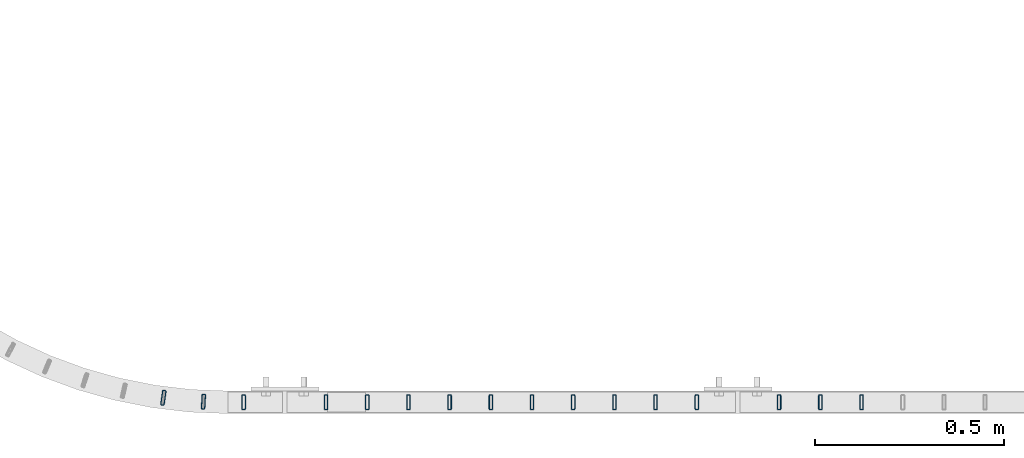
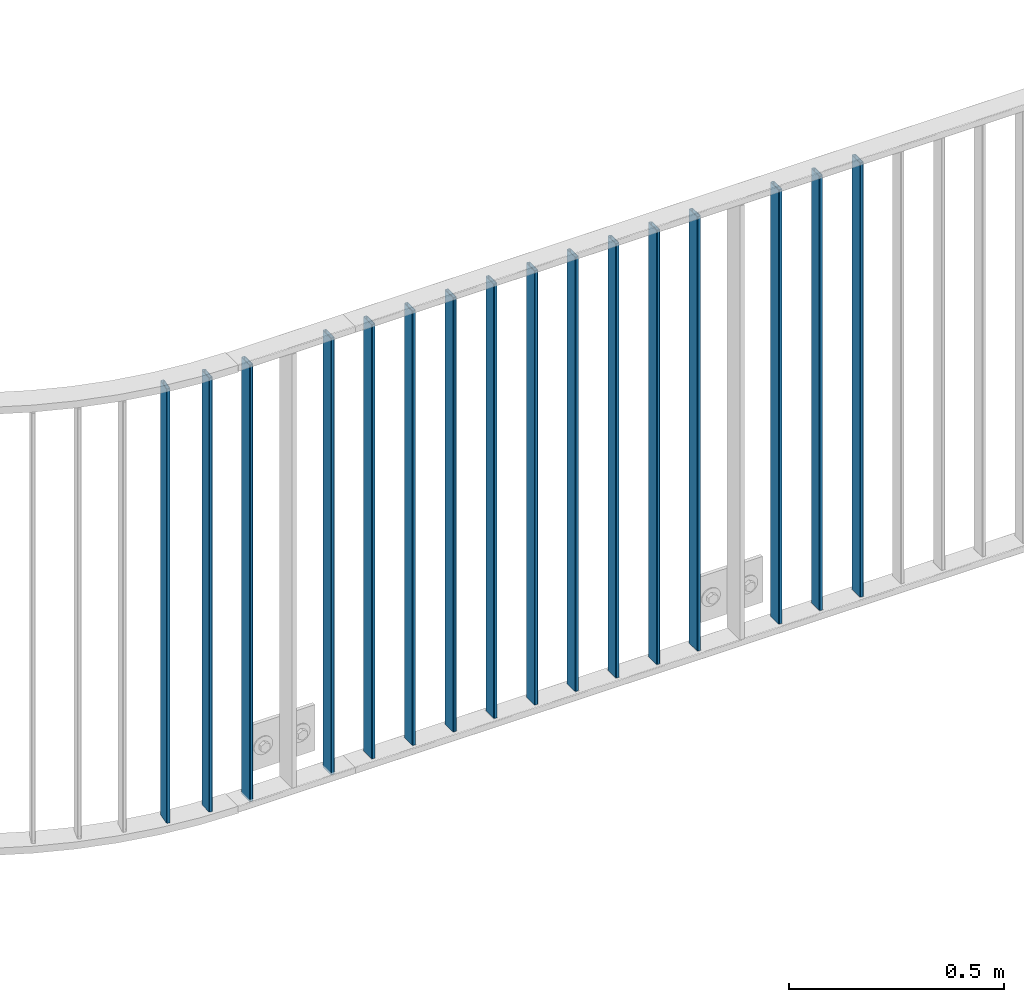
# One storey, part 18 of 156: 16 beams, 2 elements without a shape of their own.
"""IFC2X3 building model written with IfcOpenShell, lengths in millimetres."""

from ifc_helpers import new_model, si_unit, frame, origin_with_axes, origin_2d_with_axis, place, context, subcontext, project, spatial, hollow_rectangle, extrude, clip, halfspace, material, type_object, element, aggregate, save


model = new_model("IFC2X3")

# Units and contexts
model_context = context("Model", 3, precision=1e-05, world=origin_with_axes())
body_context = subcontext(model_context, "Body", "Model", "MODEL_VIEW")
ifc_project = project(units=[si_unit("LENGTHUNIT", "METRE", prefix="MILLI"), si_unit("AREAUNIT", "SQUARE_METRE"), si_unit("VOLUMEUNIT", "CUBIC_METRE"), si_unit("MASSUNIT", "GRAM", prefix="KILO"), si_unit("TIMEUNIT", "SECOND"), si_unit("PLANEANGLEUNIT", "RADIAN"), si_unit("SOLIDANGLEUNIT", "STERADIAN"), si_unit("THERMODYNAMICTEMPERATUREUNIT", "DEGREE_CELSIUS"), si_unit("LUMINOUSINTENSITYUNIT", "LUMEN")], contexts=[model_context])

# Site, building, storey
site_placement = place(None, origin_with_axes())
site = spatial("IfcSite", under=ifc_project, at=site_placement, CompositionType="ELEMENT")
building_placement = place(site_placement, origin_with_axes())
building = spatial("IfcBuilding", under=site, at=building_placement, Name="Undefined", CompositionType="ELEMENT")
storey_placement = place(building_placement, origin_with_axes())
storey = spatial("IfcBuildingStorey", under=building, at=storey_placement, Name="Undefined", CompositionType="ELEMENT", Elevation=0.0)

# Assembly, beams
assembly_1_placement = place(storey_placement, origin_with_axes())
assembly_1 = element("IfcElementAssembly", 1, at=assembly_1_placement, inside=storey, AssemblyPlace="NOTDEFINED", PredefinedType="RIGID_FRAME")
ifc_material = material(Name="STEEL/S235JR")
beam_type = type_object("IfcBeamType", Name="K40/10/1.5", PredefinedType="NOTDEFINED")
beam_1_placement = place(assembly_1_placement, frame((28384.3403545972, 8481.68386392733, 3980.00000000003), z_axis=(0.0588596310004505, 0.998266269007669, 0.0), x_axis=(0.0, 0.0, -1.0)))
beam_1 = element("IfcBeam", 2, at=beam_1_placement, type_object=beam_type, material=ifc_material, ObjectType="K40/10/1.5", context=body_context, shape_type="SweptSolid", body=[
    extrude(hollow_rectangle(XDim=10.0, YDim=40.0, WallThickness=1.5, InnerFilletRadius=1.5, OuterFilletRadius=3.0, at=origin_2d_with_axis()), frame((1230.0, 0.0, 0.0), z_axis=(-1.0, 0.0, 0.0), x_axis=(0.0, -1.0, 0.0)), (0.0, 0.0, 1.0), 1230.0),
])
beam_2_placement = place(assembly_1_placement, frame((28278.1852240979, 8491.69336136785, 3980.00000000003), z_axis=(0.143049714033372, 0.989715504230873, 0.0), x_axis=(0.0, 0.0, -1.0)))
beam_2 = element("IfcBeam", 3, at=beam_2_placement, type_object=beam_type, material=ifc_material, ObjectType="K40/10/1.5", context=body_context, shape_type="SweptSolid", body=[
    extrude(hollow_rectangle(XDim=10.0, YDim=40.0, WallThickness=1.5, InnerFilletRadius=1.5, OuterFilletRadius=3.0, at=origin_2d_with_axis()), frame((1230.0, 0.0, 0.0), z_axis=(-1.0, 0.0, 0.0), x_axis=(0.0, -1.0, 0.0)), (0.0, 0.0, 1.0), 1230.0),
])
beam_3_placement = place(assembly_1_placement, frame((28490.919999999, 8480.00209815304, 3980.00000000003), z_axis=(0.0, 1.0, 0.0), x_axis=(0.0, 0.0, -1.0)))
beam_3 = element("IfcBeam", 4, at=beam_3_placement, type_object=beam_type, material=ifc_material, ObjectType="K40/10/1.5", context=body_context, shape_type="Clipping", body=[
    clip(extrude(hollow_rectangle(XDim=10.0, YDim=40.0, WallThickness=1.5, InnerFilletRadius=1.5, OuterFilletRadius=3.0, at=origin_2d_with_axis()), frame((1237.00000000003, 0.0, 0.0), z_axis=(-1.0, 0.0, 0.0), x_axis=(0.0, -1.0, 0.0)), (0.0, 0.0, 1.0), 1237.0), halfspace(frame((1237.00000000003, 4.34248751949781, 47.3810900558092), z_axis=(1.0, 0.0, 0.0), x_axis=(0.0, -0.768354814194188, -0.640024124158313)), False)),
])
beam_4_placement = place(assembly_1_placement, frame((28709.099999999, 8480.00209815304, 3980.00000000003), z_axis=(0.0, 1.0, 0.0), x_axis=(0.0, 0.0, -1.0)))
beam_4 = element("IfcBeam", 5, at=beam_4_placement, type_object=beam_type, material=ifc_material, ObjectType="K40/10/1.5", context=body_context, shape_type="Clipping", body=[
    clip(extrude(hollow_rectangle(XDim=10.0, YDim=40.0, WallThickness=1.5, InnerFilletRadius=1.5, OuterFilletRadius=3.0, at=origin_2d_with_axis()), frame((1237.00000000003, 0.0, 0.0), z_axis=(-1.0, 0.0, 0.0), x_axis=(0.0, -1.0, 0.0)), (0.0, 0.0, 1.0), 1237.0), halfspace(frame((1237.00000000003, 4.34248751949781, 47.3810900558092), z_axis=(1.0, 0.0, 0.0), x_axis=(0.0, -0.768354814194188, -0.640024124158313)), False)),
])
aggregate(assembly_1, [beam_1, beam_2, beam_3, beam_4])

assembly_2_placement = place(storey_placement, origin_with_axes())
assembly_2 = element("IfcElementAssembly", 6, at=assembly_2_placement, inside=storey, AssemblyPlace="NOTDEFINED", PredefinedType="RIGID_FRAME")
beam_5_placement = place(assembly_2_placement, frame((28818.189999999, 8480.00209815304, 3980.00000000003), z_axis=(0.0, 1.0, 0.0), x_axis=(0.0, 0.0, -1.0)))
beam_5 = element("IfcBeam", 7, at=beam_5_placement, type_object=beam_type, material=ifc_material, ObjectType="K40/10/1.5", context=body_context, shape_type="Clipping", body=[
    clip(extrude(hollow_rectangle(XDim=10.0, YDim=40.0, WallThickness=1.5, InnerFilletRadius=1.5, OuterFilletRadius=3.0, at=origin_2d_with_axis()), frame((1230.0, 0.0, 0.0), z_axis=(-1.0, 0.0, 0.0), x_axis=(0.0, -1.0, 0.0)), (0.0, 0.0, 1.0), 1230.0), halfspace(frame((-6.99999999997453, -4.34248751950508, 47.3810900558092), z_axis=(-1.0, 0.0, 0.0), x_axis=(0.0, 0.7683548141934, -0.640024124159258)), False)),
])
beam_6_placement = place(assembly_2_placement, frame((28927.279999999, 8480.00209815304, 3980.00000000003), z_axis=(0.0, 1.0, 0.0), x_axis=(0.0, 0.0, -1.0)))
beam_6 = element("IfcBeam", 8, at=beam_6_placement, type_object=beam_type, material=ifc_material, ObjectType="K40/10/1.5", context=body_context, shape_type="Clipping", body=[
    clip(extrude(hollow_rectangle(XDim=10.0, YDim=40.0, WallThickness=1.5, InnerFilletRadius=1.5, OuterFilletRadius=3.0, at=origin_2d_with_axis()), frame((1230.0, 0.0, 0.0), z_axis=(-1.0, 0.0, 0.0), x_axis=(0.0, -1.0, 0.0)), (0.0, 0.0, 1.0), 1230.0), halfspace(frame((-6.99999999997453, -4.34248751950508, 47.3810900558092), z_axis=(-1.0, 0.0, 0.0), x_axis=(0.0, 0.7683548141934, -0.640024124159258)), False)),
])
beam_7_placement = place(assembly_2_placement, frame((29036.369999999, 8480.00209815304, 3980.00000000003), z_axis=(0.0, 1.0, 0.0), x_axis=(0.0, 0.0, -1.0)))
beam_7 = element("IfcBeam", 9, at=beam_7_placement, type_object=beam_type, material=ifc_material, ObjectType="K40/10/1.5", context=body_context, shape_type="Clipping", body=[
    clip(extrude(hollow_rectangle(XDim=10.0, YDim=40.0, WallThickness=1.5, InnerFilletRadius=1.5, OuterFilletRadius=3.0, at=origin_2d_with_axis()), frame((1230.0, 0.0, 0.0), z_axis=(-1.0, 0.0, 0.0), x_axis=(0.0, -1.0, 0.0)), (0.0, 0.0, 1.0), 1230.0), halfspace(frame((-6.99999999997453, -4.34248751950508, 47.3810900558092), z_axis=(-1.0, 0.0, 0.0), x_axis=(0.0, 0.7683548141934, -0.640024124159258)), False)),
])
beam_8_placement = place(assembly_2_placement, frame((29690.909999999, 8480.00209815304, 3980.00000000003), z_axis=(0.0, 1.0, 0.0), x_axis=(0.0, 0.0, -1.0)))
beam_8 = element("IfcBeam", 10, at=beam_8_placement, type_object=beam_type, material=ifc_material, ObjectType="K40/10/1.5", context=body_context, shape_type="Clipping", body=[
    clip(extrude(hollow_rectangle(XDim=10.0, YDim=40.0, WallThickness=1.5, InnerFilletRadius=1.5, OuterFilletRadius=3.0, at=origin_2d_with_axis()), frame((1230.0, 0.0, 0.0), z_axis=(-1.0, 0.0, 0.0), x_axis=(0.0, -1.0, 0.0)), (0.0, 0.0, 1.0), 1230.0), halfspace(frame((-6.99999999997453, -4.34248751950508, 47.3810900558092), z_axis=(-1.0, 0.0, 0.0), x_axis=(0.0, 0.7683548141934, -0.640024124159258)), False)),
])
beam_9_placement = place(assembly_2_placement, frame((29581.819999999, 8480.00209815304, 3980.00000000003), z_axis=(0.0, 1.0, 0.0), x_axis=(0.0, 0.0, -1.0)))
beam_9 = element("IfcBeam", 11, at=beam_9_placement, type_object=beam_type, material=ifc_material, ObjectType="K40/10/1.5", context=body_context, shape_type="Clipping", body=[
    clip(extrude(hollow_rectangle(XDim=10.0, YDim=40.0, WallThickness=1.5, InnerFilletRadius=1.5, OuterFilletRadius=3.0, at=origin_2d_with_axis()), frame((1230.0, 0.0, 0.0), z_axis=(-1.0, 0.0, 0.0), x_axis=(0.0, -1.0, 0.0)), (0.0, 0.0, 1.0), 1230.0), halfspace(frame((-6.99999999997453, -4.34248751950508, 47.3810900558092), z_axis=(-1.0, 0.0, 0.0), x_axis=(0.0, 0.7683548141934, -0.640024124159258)), False)),
])
beam_10_placement = place(assembly_2_placement, frame((29472.729999999, 8480.00209815304, 3980.00000000003), z_axis=(0.0, 1.0, 0.0), x_axis=(0.0, 0.0, -1.0)))
beam_10 = element("IfcBeam", 12, at=beam_10_placement, type_object=beam_type, material=ifc_material, ObjectType="K40/10/1.5", context=body_context, shape_type="Clipping", body=[
    clip(extrude(hollow_rectangle(XDim=10.0, YDim=40.0, WallThickness=1.5, InnerFilletRadius=1.5, OuterFilletRadius=3.0, at=origin_2d_with_axis()), frame((1230.0, 0.0, 0.0), z_axis=(-1.0, 0.0, 0.0), x_axis=(0.0, -1.0, 0.0)), (0.0, 0.0, 1.0), 1230.0), halfspace(frame((-6.99999999997453, -4.34248751950508, 47.3810900558092), z_axis=(-1.0, 0.0, 0.0), x_axis=(0.0, 0.7683548141934, -0.640024124159258)), False)),
])
beam_11_placement = place(assembly_2_placement, frame((29363.639999999, 8480.00209815304, 3980.00000000003), z_axis=(0.0, 1.0, 0.0), x_axis=(0.0, 0.0, -1.0)))
beam_11 = element("IfcBeam", 13, at=beam_11_placement, type_object=beam_type, material=ifc_material, ObjectType="K40/10/1.5", context=body_context, shape_type="Clipping", body=[
    clip(extrude(hollow_rectangle(XDim=10.0, YDim=40.0, WallThickness=1.5, InnerFilletRadius=1.5, OuterFilletRadius=3.0, at=origin_2d_with_axis()), frame((1230.0, 0.0, 0.0), z_axis=(-1.0, 0.0, 0.0), x_axis=(0.0, -1.0, 0.0)), (0.0, 0.0, 1.0), 1230.0), halfspace(frame((-6.99999999997453, -4.34248751950508, 47.3810900558092), z_axis=(-1.0, 0.0, 0.0), x_axis=(0.0, 0.7683548141934, -0.640024124159258)), False)),
])
beam_12_placement = place(assembly_2_placement, frame((29254.549999999, 8480.00209815304, 3980.00000000003), z_axis=(0.0, 1.0, 0.0), x_axis=(0.0, 0.0, -1.0)))
beam_12 = element("IfcBeam", 14, at=beam_12_placement, type_object=beam_type, material=ifc_material, ObjectType="K40/10/1.5", context=body_context, shape_type="Clipping", body=[
    clip(extrude(hollow_rectangle(XDim=10.0, YDim=40.0, WallThickness=1.5, InnerFilletRadius=1.5, OuterFilletRadius=3.0, at=origin_2d_with_axis()), frame((1230.0, 0.0, 0.0), z_axis=(-1.0, 0.0, 0.0), x_axis=(0.0, -1.0, 0.0)), (0.0, 0.0, 1.0), 1230.0), halfspace(frame((-6.99999999997453, -4.34248751950508, 47.3810900558092), z_axis=(-1.0, 0.0, 0.0), x_axis=(0.0, 0.7683548141934, -0.640024124159258)), False)),
])
beam_13_placement = place(assembly_2_placement, frame((29145.459999999, 8480.00209815304, 3980.00000000003), z_axis=(0.0, 1.0, 0.0), x_axis=(0.0, 0.0, -1.0)))
beam_13 = element("IfcBeam", 15, at=beam_13_placement, type_object=beam_type, material=ifc_material, ObjectType="K40/10/1.5", context=body_context, shape_type="Clipping", body=[
    clip(extrude(hollow_rectangle(XDim=10.0, YDim=40.0, WallThickness=1.5, InnerFilletRadius=1.5, OuterFilletRadius=3.0, at=origin_2d_with_axis()), frame((1230.0, 0.0, 0.0), z_axis=(-1.0, 0.0, 0.0), x_axis=(0.0, -1.0, 0.0)), (0.0, 0.0, 1.0), 1230.0), halfspace(frame((-6.99999999997453, -4.34248751950508, 47.3810900558092), z_axis=(-1.0, 0.0, 0.0), x_axis=(0.0, 0.7683548141934, -0.640024124159258)), False)),
])
beam_14_placement = place(assembly_2_placement, frame((30127.269999999, 8480.00209765299, 3980.00000000003), z_axis=(0.0, 1.0, 0.0), x_axis=(0.0, 0.0, -1.0)))
beam_14 = element("IfcBeam", 16, at=beam_14_placement, type_object=beam_type, material=ifc_material, ObjectType="K40/10/1.5", context=body_context, shape_type="Clipping", body=[
    clip(extrude(hollow_rectangle(XDim=10.0, YDim=40.0, WallThickness=1.5, InnerFilletRadius=1.5, OuterFilletRadius=3.0, at=origin_2d_with_axis()), frame((1230.0, 0.0, 0.0), z_axis=(-1.0, 0.0, 0.0), x_axis=(0.0, -1.0, 0.0)), (0.0, 0.0, 1.0), 1230.0), halfspace(frame((-6.99999999997453, -4.34248751950508, 47.3810900558092), z_axis=(-1.0, 0.0, 0.0), x_axis=(0.0, 0.7683548141934, -0.640024124159258)), False)),
])
beam_15_placement = place(assembly_2_placement, frame((30018.179999999, 8480.00209765299, 3980.00000000003), z_axis=(0.0, 1.0, 0.0), x_axis=(0.0, 0.0, -1.0)))
beam_15 = element("IfcBeam", 17, at=beam_15_placement, type_object=beam_type, material=ifc_material, ObjectType="K40/10/1.5", context=body_context, shape_type="Clipping", body=[
    clip(extrude(hollow_rectangle(XDim=10.0, YDim=40.0, WallThickness=1.5, InnerFilletRadius=1.5, OuterFilletRadius=3.0, at=origin_2d_with_axis()), frame((1230.0, 0.0, 0.0), z_axis=(-1.0, 0.0, 0.0), x_axis=(0.0, -1.0, 0.0)), (0.0, 0.0, 1.0), 1230.0), halfspace(frame((-6.99999999997453, -4.34248751950508, 47.3810900558092), z_axis=(-1.0, 0.0, 0.0), x_axis=(0.0, 0.7683548141934, -0.640024124159258)), False)),
])
beam_16_placement = place(assembly_2_placement, frame((29909.089999999, 8480.00209765299, 3980.00000000003), z_axis=(0.0, 1.0, 0.0), x_axis=(0.0, 0.0, -1.0)))
beam_16 = element("IfcBeam", 18, at=beam_16_placement, type_object=beam_type, material=ifc_material, ObjectType="K40/10/1.5", context=body_context, shape_type="Clipping", body=[
    clip(extrude(hollow_rectangle(XDim=10.0, YDim=40.0, WallThickness=1.5, InnerFilletRadius=1.5, OuterFilletRadius=3.0, at=origin_2d_with_axis()), frame((1230.0, 0.0, 0.0), z_axis=(-1.0, 0.0, 0.0), x_axis=(0.0, -1.0, 0.0)), (0.0, 0.0, 1.0), 1230.0), halfspace(frame((-6.99999999997453, -4.34248751950508, 47.3810900558092), z_axis=(-1.0, 0.0, 0.0), x_axis=(0.0, 0.7683548141934, -0.640024124159258)), False)),
])
aggregate(assembly_2, [beam_5, beam_6, beam_7, beam_8, beam_9, beam_10, beam_11, beam_12, beam_13, beam_14, beam_15, beam_16])

save(model, "model.ifc")
